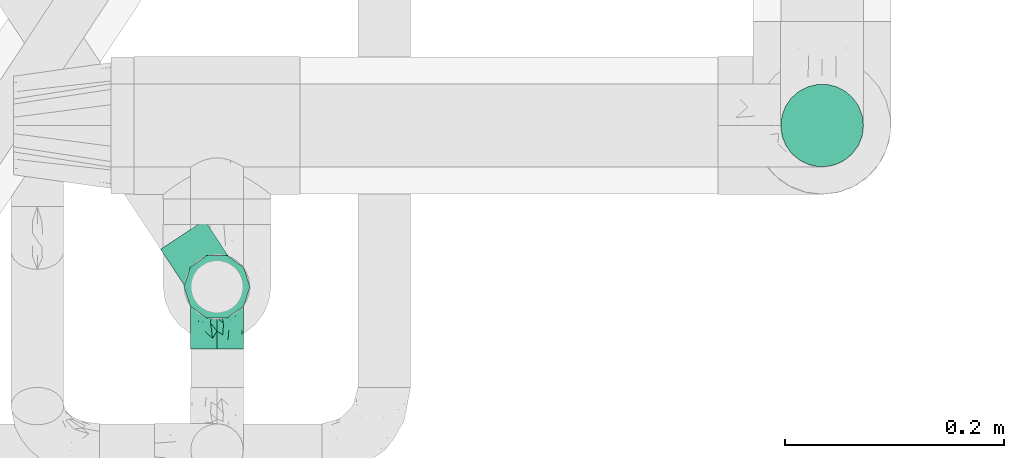
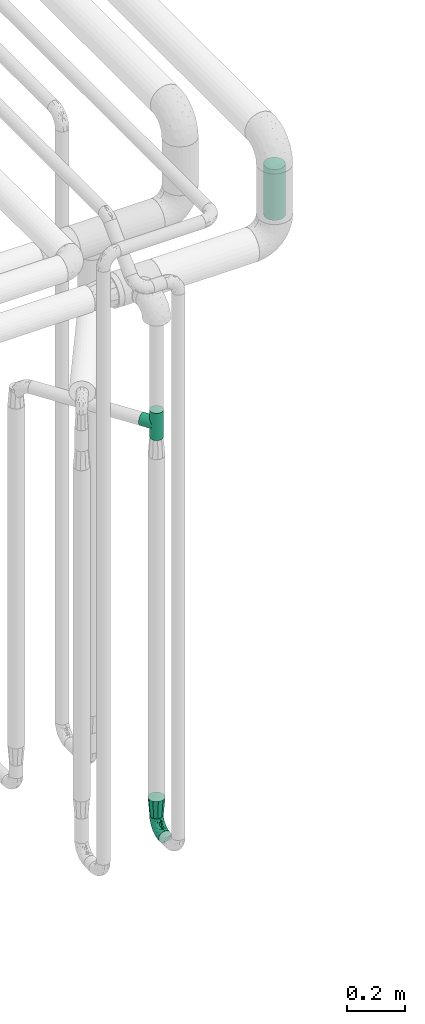
# One storey, part 667 of 827: 3 flow fittings, 1 flow segment.
"""IFC2X3 building model written with IfcOpenShell, lengths in millimetres."""

from ifc_helpers import new_model, entity, si_unit, converted_unit, derived_unit, direction, frame, origin, origin_2d_with_axis, place, context, subcontext, project, spatial, circle, extrude, faceted_brep, source, transform, mapped, material, type_object, type_shapes, element, save


model = new_model("IFC2X3")

# Units and contexts
model_context = context("Model", 3, precision=0.01, world=origin(), true_north=direction((6.12303176911189e-17, 1.0)))
body_context = subcontext(model_context, "Body", "Model", "MODEL_VIEW")
ifc_project = project(units=[si_unit("LENGTHUNIT", "METRE", prefix="MILLI"), si_unit("AREAUNIT", "SQUARE_METRE"), si_unit("VOLUMEUNIT", "CUBIC_METRE"), converted_unit("PLANEANGLEUNIT", "DEGREE", entity("IfcRatioMeasure", 0.0174532925199433), si_unit("PLANEANGLEUNIT", "RADIAN"), dimensions=[0, 0, 0, 0, 0, 0, 0]), si_unit("MASSUNIT", "GRAM", prefix="KILO"), derived_unit("MASSDENSITYUNIT", [(si_unit("MASSUNIT", "GRAM", prefix="KILO"), 1), (si_unit("LENGTHUNIT", "METRE"), -3)]), derived_unit("MOMENTOFINERTIAUNIT", [(si_unit("LENGTHUNIT", "METRE"), 4)]), si_unit("TIMEUNIT", "SECOND"), si_unit("FREQUENCYUNIT", "HERTZ"), si_unit("THERMODYNAMICTEMPERATUREUNIT", "DEGREE_CELSIUS"), derived_unit("THERMALTRANSMITTANCEUNIT", [(si_unit("MASSUNIT", "GRAM", prefix="KILO"), 1), (si_unit("THERMODYNAMICTEMPERATUREUNIT", "KELVIN"), -1), (si_unit("TIMEUNIT", "SECOND"), -3)]), derived_unit("VOLUMETRICFLOWRATEUNIT", [(si_unit("LENGTHUNIT", "METRE"), 3), (si_unit("TIMEUNIT", "SECOND"), -1)]), derived_unit("MASSFLOWRATEUNIT", [(si_unit("MASSUNIT", "GRAM", prefix="KILO"), 1), (si_unit("TIMEUNIT", "SECOND"), -1)]), derived_unit("ROTATIONALFREQUENCYUNIT", [(si_unit("TIMEUNIT", "SECOND"), -1)]), si_unit("ELECTRICCURRENTUNIT", "AMPERE"), si_unit("ELECTRICVOLTAGEUNIT", "VOLT"), si_unit("POWERUNIT", "WATT"), si_unit("FORCEUNIT", "NEWTON", prefix="KILO"), si_unit("ILLUMINANCEUNIT", "LUX"), si_unit("LUMINOUSFLUXUNIT", "LUMEN"), si_unit("LUMINOUSINTENSITYUNIT", "CANDELA"), derived_unit("USERDEFINED", [(si_unit("MASSUNIT", "GRAM", prefix="KILO"), -1), (si_unit("LENGTHUNIT", "METRE"), -2), (si_unit("TIMEUNIT", "SECOND"), 3), (si_unit("LUMINOUSFLUXUNIT", "LUMEN"), 1)]), derived_unit("LINEARVELOCITYUNIT", [(si_unit("LENGTHUNIT", "METRE"), 1), (si_unit("TIMEUNIT", "SECOND"), -1)]), si_unit("PRESSUREUNIT", "PASCAL"), derived_unit("USERDEFINED", [(si_unit("LENGTHUNIT", "METRE"), -2), (si_unit("MASSUNIT", "GRAM", prefix="KILO"), 1), (si_unit("TIMEUNIT", "SECOND"), -2)]), derived_unit("LINEARFORCEUNIT", [(si_unit("MASSUNIT", "GRAM", prefix="KILO"), 1), (si_unit("LENGTHUNIT", "METRE"), 1), (si_unit("TIMEUNIT", "SECOND"), -2), (si_unit("LENGTHUNIT", "METRE"), -1)]), derived_unit("PLANARFORCEUNIT", [(si_unit("MASSUNIT", "GRAM", prefix="KILO"), 1), (si_unit("LENGTHUNIT", "METRE"), 1), (si_unit("TIMEUNIT", "SECOND"), -2), (si_unit("LENGTHUNIT", "METRE"), -2)])], contexts=[model_context])

# Site, building, storey
site_placement = place(None, origin())
site = spatial("IfcSite", under=ifc_project, at=site_placement, CompositionType="ELEMENT")
building_placement = place(site_placement, origin())
building = spatial("IfcBuilding", under=site, at=building_placement, CompositionType="ELEMENT")
storey_placement = place(building_placement, frame((0.0, 0.0, 28200.0)))
storey = spatial("IfcBuildingStorey", under=building, at=storey_placement, Name="08", CompositionType="ELEMENT", Elevation=28200.0)

# Flow segment
pipe_segment_type = type_object("IfcPipeSegmentType", PredefinedType="NOTDEFINED")
flow_segment_placement = place(storey_placement, frame((48805.69, 13894.16, 2692.43)))
element("IfcFlowSegment", 1, at=flow_segment_placement, inside=storey, type_object=pipe_segment_type, context=body_context, shape_type="SweptSolid", body=[
    extrude(circle(Radius=37.75, at=origin_2d_with_axis()), frame((39.35, 39.35, 0.0)), (0.0, 0.0, 1.0), 212.567197891267),
])

# Flow fittings
ifc_material = material()
pipe_fitting_type_1 = type_object("IfcPipeFittingType", Name="ADSK_1", PredefinedType="NOTDEFINED", material=ifc_material)
shared_shape_1 = source(origin(), body_context, "Body", "Brep", [
    faceted_brep([(-57.0, 12.07, -20.91), (-57.0, 6.25, -23.33), (-57.0, 0.0, -24.15), (-57.0, -6.25, -23.33), (-57.0, -12.08, -20.91), (-57.0, -17.08, -17.08), (-57.0, -20.91, -12.08), (-57.0, -23.33, -6.25), (-57.0, -24.15, 0.0), (-57.0, -23.33, 6.25), (-57.0, -20.91, 12.07), (-57.0, -17.08, 17.08), (-57.0, -12.08, 20.91), (-57.0, -6.25, 23.33), (-57.0, 0.0, 24.15), (-57.0, 6.25, 23.33), (-57.0, 12.07, 20.91), (-57.0, 17.08, 17.08), (-57.0, 20.91, 12.07), (-57.0, 23.33, 6.25), (-57.0, 24.15, 0.0), (-57.0, 23.33, -6.25), (-57.0, 20.91, -12.08), (-57.0, 17.08, -17.08), (0.0, 57.0, -24.15), (-6.25, 57.0, -23.33), (-12.07, 57.0, -20.91), (-17.08, 57.0, -17.08), (-20.91, 57.0, -12.08), (-23.33, 57.0, -6.25), (-24.15, 57.0, 0.0), (-23.33, 57.0, 6.25), (-20.91, 57.0, 12.07), (-17.08, 57.0, 17.08), (-12.07, 57.0, 20.91), (-6.25, 57.0, 23.33), (0.0, 57.0, 24.15), (6.25, 57.0, 23.33), (12.08, 57.0, 20.91), (17.08, 57.0, 17.08), (20.91, 57.0, 12.07), (23.33, 57.0, 6.25), (24.15, 57.0, 0.0), (23.33, 57.0, -6.25), (20.91, 57.0, -12.08), (17.08, 57.0, -17.08), (12.08, 57.0, -20.91), (6.25, 57.0, -23.33), (14.9, 21.14, 6.17), (13.61, 24.64, 12.48), (6.23, 8.95, 8.98), (-41.47, -21.06, 0.0), (-41.92, -18.38, 13.72), (-24.64, -13.61, 12.48), (-37.37, -13.24, 18.15), (-6.8, -4.93, 8.18), (-21.76, -15.19, 6.22), (-12.78, -9.18, 0.0), (-37.73, -20.51, 7.75), (-7.38, 7.38, 20.24), (-23.37, -4.26, 20.42), (-11.9, -3.19, 15.86), (-42.14, -8.7, 21.82), (13.24, 37.37, 18.15), (9.33, 23.53, 16.85), (4.26, 23.37, 20.42), (2.77, 10.92, 15.55), (-29.46, 0.91, 23.52), (-44.13, 20.56, 15.69), (-39.25, 26.33, 10.88), (-49.02, 22.92, 9.96), (-34.58, 23.87, 17.15), (-15.8, 6.8, 22.81), (-8.67, 20.47, 23.88), (-18.12, 12.9, 24.08), (-48.29, 14.92, 19.65), (-44.06, -2.85, 23.78), (-9.23, 48.95, 22.58), (-3.78, 42.74, 24.07), (-40.34, 4.26, 24.09), (-44.02, 26.14, 5.46), (-44.04, 9.88, 22.74), (-4.95, 16.87, 22.52), (-2.75, 1.43, 12.5), (-25.48, 40.98, 10.71), (20.51, 37.73, 7.75), (18.38, 41.92, 13.72), (8.7, 42.14, 21.82), (-25.95, -17.97, 0.0), (2.85, 44.06, 23.78), (21.06, 41.47, 0.0), (17.97, 25.95, 0.0), (-24.04, -9.27, 17.13), (-33.26, 33.26, 5.86), (-28.55, 40.57, 0.0), (-40.57, 28.55, 0.0), (-25.29, 47.19, 4.06), (-27.01, 31.1, 16.77), (-15.7, 43.95, 19.9), (-20.27, 45.22, 15.61), (-30.53, 31.98, 12.64), (-11.28, 38.33, 22.92), (-9.97, 27.88, 24.09), (-20.15, 30.26, 21.25), (-31.25, 11.75, 23.64), (-28.75, 7.23, 24.15), (-29.53, 18.06, 22.27), (-28.44, 24.21, 20.02), (-37.55, 17.7, 20.26), (-15.88, 29.25, 22.99), (-20.82, 20.82, 23.44), (-0.91, 29.46, 23.52), (-13.5, -7.67, 12.04), (1.49, 1.56, 5.16), (8.86, 10.35, 4.59), (0.38, -0.38, 0.0), (9.18, 12.78, 0.0), (-37.37, -13.24, -18.15), (8.86, 10.35, -4.59), (-45.22, 20.27, -15.61), (-43.95, 15.7, -19.9), (-38.33, 11.28, -22.92), (-48.95, 9.23, -22.58), (-47.19, 25.29, -4.06), (-33.26, 33.26, -5.86), (18.38, 41.92, -13.72), (-30.26, 20.15, -21.25), (2.85, 44.06, -23.78), (-4.26, 40.34, -24.09), (-40.98, 25.48, -10.71), (-41.92, -18.38, -13.72), (9.25, 23.5, -16.92), (4.26, 23.37, -20.42), (13.24, 37.37, -18.15), (-37.73, -20.51, -7.75), (-11.75, 31.25, -23.64), (-7.23, 28.75, -24.15), (-12.9, 18.12, -24.08), (8.7, 42.14, -21.82), (-44.06, -2.85, -23.78), (-6.8, 15.8, -22.81), (-20.47, 8.67, -23.88), (-24.64, -13.61, -12.48), (-42.74, 3.78, -24.07), (-18.06, 29.53, -22.27), (-24.21, 28.44, -20.02), (-27.88, 9.97, -24.09), (-31.1, 27.01, -16.77), (-26.14, 44.02, -5.46), (14.9, 21.14, -6.17), (20.51, 37.73, -7.75), (-9.88, 44.04, -22.74), (-20.56, 44.13, -15.69), (-21.76, -15.19, -6.22), (-13.5, -7.67, -12.04), (-24.14, -9.76, -16.74), (-11.9, -3.19, -15.86), (-14.92, 48.29, -19.65), (-23.37, -4.26, -20.42), (-0.91, 29.46, -23.52), (-26.33, 39.25, -10.88), (-23.87, 34.58, -17.15), (-42.14, -8.7, -21.82), (-22.92, 49.02, -9.96), (13.61, 24.64, -12.48), (-31.98, 30.53, -12.64), (-16.87, 4.95, -22.52), (-17.7, 37.55, -20.26), (-29.25, 15.88, -22.99), (-20.82, 20.82, -23.44), (-29.46, 0.91, -23.52), (-7.38, 7.38, -20.24), (2.77, 10.92, -15.55), (6.23, 8.95, -8.98), (-6.8, -4.93, -8.18), (-2.81, 1.41, -12.54), (1.49, 1.56, -5.16)], [[[0, 1, 2, 3, 4, 5, 6, 7, 8, 9, 10, 11, 12, 13, 14, 15, 16, 17, 18, 19, 20, 21, 22, 23]], [[24, 25, 26, 27, 28, 29, 30, 31, 32, 33, 34, 35, 36, 37, 38, 39, 40, 41, 42, 43, 44, 45, 46, 47]], [[48, 49, 50]], [[9, 8, 51]], [[52, 53, 54]], [[55, 56, 57]], [[10, 58, 52]], [[9, 58, 10]], [[59, 60, 61]], [[54, 12, 11]], [[54, 62, 12]], [[63, 39, 38]], [[64, 65, 66]], [[62, 60, 67]], [[68, 69, 70]], [[71, 69, 68]], [[72, 73, 74]], [[16, 75, 17]], [[13, 76, 14]], [[35, 77, 78]], [[14, 79, 15]], [[17, 68, 18]], [[14, 76, 79]], [[20, 19, 80]], [[70, 19, 18]], [[81, 15, 79]], [[15, 81, 16]], [[73, 72, 82]], [[66, 83, 50]], [[32, 31, 84]], [[85, 86, 49]], [[63, 87, 65]], [[56, 58, 88]], [[36, 89, 37]], [[85, 41, 40]], [[36, 35, 78]], [[90, 41, 85]], [[40, 39, 86]], [[12, 62, 13]], [[86, 85, 40]], [[48, 85, 49]], [[85, 91, 90]], [[87, 38, 37]], [[92, 60, 54]], [[80, 69, 93]], [[93, 94, 95]], [[10, 52, 11]], [[94, 96, 30]], [[97, 98, 99]], [[80, 93, 95]], [[100, 97, 84]], [[99, 98, 33]], [[101, 102, 78]], [[103, 101, 98]], [[96, 31, 30]], [[77, 98, 101]], [[77, 35, 34]], [[34, 33, 98]], [[9, 51, 58]], [[87, 63, 38]], [[104, 105, 74]], [[106, 103, 107]], [[106, 81, 104]], [[75, 68, 17]], [[108, 107, 71]], [[33, 32, 99]], [[109, 103, 110]], [[101, 109, 102]], [[89, 78, 111]], [[53, 52, 58]], [[54, 11, 52]], [[60, 62, 54]], [[88, 58, 51]], [[76, 62, 67]], [[53, 112, 92]], [[60, 59, 72]], [[39, 63, 86]], [[49, 86, 63]], [[89, 87, 37]], [[42, 41, 90]], [[111, 82, 65]], [[111, 65, 87]], [[65, 59, 66]], [[104, 81, 79]], [[75, 81, 108]], [[32, 84, 99]], [[97, 99, 84]], [[98, 97, 103]], [[106, 107, 108]], [[74, 102, 110]], [[111, 78, 102]], [[74, 110, 104]], [[74, 67, 72]], [[61, 92, 112]], [[66, 59, 61]], [[56, 53, 58]], [[66, 50, 49]], [[61, 112, 83]], [[66, 49, 64]], [[78, 89, 36]], [[87, 89, 111]], [[62, 76, 13]], [[79, 76, 67]], [[100, 93, 69]], [[96, 93, 84]], [[55, 113, 50]], [[113, 114, 50]], [[104, 79, 105]], [[106, 104, 110]], [[20, 80, 95]], [[85, 48, 91]], [[115, 114, 113]], [[116, 91, 48]], [[70, 80, 19]], [[93, 96, 94]], [[84, 31, 96]], [[103, 106, 110]], [[81, 106, 108]], [[103, 97, 107]], [[71, 107, 97]], [[71, 97, 100]], [[108, 71, 68]], [[79, 67, 105]], [[67, 74, 105]], [[115, 113, 57]], [[112, 56, 55]], [[56, 88, 57]], [[60, 72, 67]], [[82, 72, 59]], [[65, 82, 59]], [[82, 111, 73]], [[111, 102, 73]], [[102, 74, 73]], [[81, 75, 16]], [[68, 75, 108]], [[68, 70, 18]], [[80, 70, 69]], [[98, 77, 34]], [[78, 77, 101]], [[93, 100, 84]], [[71, 100, 69]], [[102, 109, 110]], [[101, 103, 109]], [[53, 92, 54]], [[61, 60, 92]], [[56, 112, 53]], [[83, 112, 55]], [[50, 83, 55]], [[61, 83, 66]], [[49, 63, 64]], [[65, 64, 63]], [[57, 113, 55]], [[114, 115, 116]], [[116, 48, 114]], [[48, 50, 114]], [[117, 5, 4]], [[116, 115, 118]], [[119, 120, 23]], [[121, 122, 120]], [[95, 123, 20]], [[0, 23, 120]], [[124, 95, 94]], [[125, 45, 44]], [[121, 120, 126]], [[24, 127, 128]], [[22, 21, 129]], [[0, 122, 1]], [[5, 117, 130]], [[131, 132, 133]], [[134, 88, 51]], [[135, 136, 137]], [[6, 5, 130]], [[46, 138, 47]], [[139, 3, 2]], [[140, 141, 137]], [[6, 134, 7]], [[134, 130, 142]], [[143, 2, 1]], [[144, 126, 145]], [[121, 146, 143]], [[147, 120, 119]], [[94, 148, 124]], [[149, 150, 91]], [[30, 29, 148]], [[151, 25, 128]], [[27, 152, 28]], [[134, 153, 88]], [[154, 155, 156]], [[27, 26, 157]], [[151, 26, 25]], [[155, 158, 156]], [[24, 47, 127]], [[1, 122, 143]], [[138, 132, 159]], [[160, 152, 161]], [[24, 128, 25]], [[46, 133, 138]], [[162, 117, 4]], [[148, 160, 124]], [[152, 160, 163]], [[154, 142, 155]], [[45, 125, 133]], [[133, 46, 45]], [[125, 164, 133]], [[51, 7, 134]], [[42, 90, 43]], [[165, 147, 129]], [[153, 134, 142]], [[43, 150, 44]], [[162, 4, 3]], [[141, 140, 166]], [[117, 162, 158]], [[163, 29, 28]], [[43, 90, 150]], [[123, 21, 20]], [[144, 151, 135]], [[157, 152, 27]], [[167, 145, 161]], [[23, 22, 119]], [[168, 126, 169]], [[121, 168, 146]], [[139, 143, 170]], [[142, 130, 117]], [[8, 7, 51]], [[134, 6, 130]], [[139, 162, 3]], [[170, 166, 158]], [[170, 158, 162]], [[158, 171, 156]], [[44, 150, 125]], [[91, 150, 90]], [[164, 125, 150]], [[132, 138, 133]], [[127, 138, 159]], [[131, 164, 172]], [[132, 171, 140]], [[135, 151, 128]], [[157, 151, 167]], [[22, 129, 119]], [[147, 119, 129]], [[120, 147, 126]], [[144, 145, 167]], [[137, 146, 169]], [[170, 143, 146]], [[137, 169, 135]], [[137, 159, 140]], [[171, 172, 156]], [[173, 174, 175]], [[156, 175, 154]], [[174, 57, 153]], [[132, 172, 171]], [[172, 164, 173]], [[143, 139, 2]], [[162, 139, 170]], [[138, 127, 47]], [[128, 127, 159]], [[165, 124, 160]], [[123, 124, 129]], [[149, 173, 164]], [[176, 174, 173]], [[135, 128, 136]], [[144, 135, 169]], [[150, 149, 164]], [[176, 118, 115]], [[149, 91, 116]], [[30, 148, 94]], [[163, 148, 29]], [[124, 123, 95]], [[129, 21, 123]], [[126, 144, 169]], [[151, 144, 167]], [[126, 147, 145]], [[161, 145, 147]], [[161, 147, 165]], [[167, 161, 152]], [[128, 159, 136]], [[159, 137, 136]], [[154, 153, 142]], [[132, 140, 159]], [[174, 176, 57]], [[57, 88, 153]], [[166, 140, 171]], [[158, 166, 171]], [[166, 170, 141]], [[170, 146, 141]], [[146, 137, 141]], [[151, 157, 26]], [[152, 157, 167]], [[152, 163, 28]], [[148, 163, 160]], [[120, 122, 0]], [[143, 122, 121]], [[124, 165, 129]], [[161, 165, 160]], [[146, 168, 169]], [[121, 126, 168]], [[142, 117, 155]], [[158, 155, 117]], [[175, 156, 172]], [[153, 154, 174]], [[173, 175, 172]], [[174, 154, 175]], [[164, 131, 133]], [[172, 132, 131]], [[176, 173, 118]], [[57, 176, 115]], [[173, 149, 118]], [[149, 116, 118]]]),
])
type_shapes(pipe_fitting_type_1, [shared_shape_1])
flow_fitting_1_placement = place(storey_placement, frame((48292.03, 13786.1, 400.0), z_axis=(1.0, 0.0, 3.35752990107202e-06), x_axis=(0.0, 1.0, 0.0)))
element("IfcFlowFitting", 2, at=flow_fitting_1_placement, inside=storey, type_object=pipe_fitting_type_1, material=ifc_material, Name="ADSK_1", ObjectType="ADSK_1", context=body_context, shape_type="MappedRepresentation", body=[
    mapped(shared_shape_1, transform((0.0, 0.0, 0.0), scale=1.0)),
])
pipe_fitting_type_2 = type_object("IfcPipeFittingType", Name="ADSK_1", PredefinedType="NOTDEFINED", material=ifc_material)
shared_shape_2 = source(origin(), body_context, "Body", "Brep", [
    faceted_brep([(-57.0, 12.07, -20.91), (-57.0, 6.25, -23.33), (-57.0, 0.0, -24.15), (-57.0, -6.25, -23.33), (-57.0, -12.08, -20.91), (-57.0, -17.08, -17.08), (-57.0, -20.91, -12.08), (-57.0, -23.33, -6.25), (-57.0, -24.15, 0.0), (-57.0, -23.33, 6.25), (-57.0, -20.91, 12.07), (-57.0, -17.08, 17.08), (-57.0, -12.08, 20.91), (-57.0, -6.25, 23.33), (-57.0, 0.0, 24.15), (-57.0, 6.25, 23.33), (-57.0, 12.07, 20.91), (-57.0, 17.08, 17.08), (-57.0, 20.91, 12.07), (-57.0, 23.33, 6.25), (-57.0, 24.15, 0.0), (-57.0, 23.33, -6.25), (-57.0, 20.91, -12.08), (-57.0, 17.08, -17.08), (57.0, 0.0, -24.15), (57.0, 6.25, -23.33), (57.0, 12.07, -20.91), (57.0, 17.08, -17.08), (57.0, 20.91, -12.08), (57.0, 23.33, -6.25), (57.0, 24.15, 0.0), (57.0, 23.33, 6.25), (57.0, 20.91, 12.07), (57.0, 17.08, 17.08), (57.0, 12.07, 20.91), (57.0, 6.25, 23.33), (57.0, 0.0, 24.15), (57.0, -6.25, 23.33), (57.0, -12.08, 20.91), (57.0, -17.08, 17.08), (57.0, -20.91, 12.07), (57.0, -23.33, 6.25), (57.0, -24.15, 0.0), (57.0, -23.33, -6.25), (57.0, -20.91, -12.08), (57.0, -17.08, -17.08), (57.0, -12.08, -20.91), (57.0, -6.25, -23.33), (23.27, -23.27, 6.45), (24.15, -24.15, 0.0), (-24.15, -24.15, 0.0), (20.9, -20.9, 12.1), (13.54, -13.54, 20.0), (17.52, -17.52, 16.62), (-23.27, -23.27, 6.45), (-20.9, -20.9, 12.1), (-17.52, -17.52, 16.62), (-13.54, -13.54, 20.0), (-9.19, -9.19, 22.33), (9.19, -9.19, 22.33), (4.64, -4.64, 23.7), (0.0, 0.0, 24.15), (-4.64, -4.64, 23.7), (4.64, -4.64, -23.7), (0.0, 0.0, -24.15), (-4.64, -4.64, -23.7), (-9.19, -9.19, -22.33), (9.19, -9.19, -22.33), (13.54, -13.54, -20.0), (17.52, -17.52, -16.62), (20.9, -20.9, -12.1), (23.27, -23.27, -6.45), (-13.54, -13.54, -20.0), (-17.52, -17.52, -16.62), (-23.27, -23.27, -6.45), (-20.9, -20.9, -12.1), (0.0, -57.0, -24.15), (6.25, -57.0, -23.33), (12.08, -57.0, -20.91), (17.08, -57.0, -17.08), (20.91, -57.0, -12.08), (23.33, -57.0, -6.25), (24.15, -57.0, 0.0), (23.33, -57.0, 6.25), (20.91, -57.0, 12.07), (17.08, -57.0, 17.08), (12.08, -57.0, 20.91), (6.25, -57.0, 23.33), (0.0, -57.0, 24.15), (-6.25, -57.0, 23.33), (-12.07, -57.0, 20.91), (-17.08, -57.0, 17.08), (-20.91, -57.0, 12.07), (-23.33, -57.0, 6.25), (-24.15, -57.0, 0.0), (-23.33, -57.0, -6.25), (-20.91, -57.0, -12.08), (-17.08, -57.0, -17.08), (-12.07, -57.0, -20.91), (-6.25, -57.0, -23.33)], [[[0, 1, 2, 3, 4, 5, 6, 7, 8, 9, 10, 11, 12, 13, 14, 15, 16, 17, 18, 19, 20, 21, 22, 23]], [[24, 25, 26, 27, 28, 29, 30, 31, 32, 33, 34, 35, 36, 37, 38, 39, 40, 41, 42, 43, 44, 45, 46, 47]], [[41, 40, 48]], [[42, 41, 49]], [[50, 9, 8]], [[49, 41, 48]], [[40, 51, 48]], [[39, 38, 52]], [[51, 40, 53]], [[52, 53, 39]], [[53, 40, 39]], [[50, 54, 9]], [[9, 54, 10]], [[54, 55, 10]], [[56, 57, 11]], [[11, 10, 56]], [[11, 57, 12]], [[56, 10, 55]], [[12, 57, 58]], [[52, 38, 59]], [[60, 36, 61]], [[62, 61, 14]], [[59, 37, 60]], [[37, 59, 38]], [[60, 37, 36]], [[61, 36, 35, 15, 14]], [[32, 31, 19, 18]], [[17, 16, 34, 33]], [[18, 17, 33, 32]], [[35, 34, 16, 15]], [[20, 19, 31, 30]], [[62, 13, 58]], [[13, 62, 14]], [[58, 13, 12]], [[27, 23, 22, 28]], [[22, 21, 29, 28]], [[0, 23, 27, 26]], [[20, 30, 29, 21]], [[24, 47, 63]], [[24, 64, 2, 1, 25]], [[64, 24, 63]], [[2, 64, 65]], [[26, 25, 1, 0]], [[65, 66, 3]], [[2, 65, 3]], [[66, 4, 3]], [[63, 47, 67]], [[46, 45, 68]], [[69, 68, 45]], [[44, 70, 69]], [[69, 45, 44]], [[46, 68, 67]], [[43, 42, 49]], [[7, 50, 8]], [[43, 71, 44]], [[71, 43, 49]], [[44, 71, 70]], [[72, 4, 66]], [[72, 5, 4]], [[5, 72, 73]], [[5, 73, 6]], [[74, 50, 7]], [[75, 74, 6]], [[74, 7, 6]], [[75, 6, 73]], [[46, 67, 47]], [[76, 77, 78, 79, 80, 81, 82, 83, 84, 85, 86, 87, 88, 89, 90, 91, 92, 93, 94, 95, 96, 97, 98, 99]], [[50, 94, 93]], [[54, 50, 93]], [[91, 90, 57]], [[56, 92, 91]], [[54, 93, 92]], [[58, 90, 89]], [[55, 54, 92]], [[56, 55, 92]], [[58, 57, 90]], [[88, 61, 62]], [[58, 89, 62]], [[56, 91, 57]], [[62, 89, 88]], [[60, 88, 87]], [[86, 59, 87]], [[84, 83, 48]], [[53, 85, 84]], [[52, 86, 85]], [[49, 83, 82]], [[59, 60, 87]], [[52, 59, 86]], [[49, 48, 83]], [[51, 53, 84]], [[48, 51, 84]], [[52, 85, 53]], [[88, 60, 61]], [[82, 81, 49]], [[71, 49, 81]], [[69, 80, 79]], [[79, 78, 68]], [[71, 81, 80]], [[67, 78, 77]], [[70, 71, 80]], [[69, 70, 80]], [[67, 68, 78]], [[76, 64, 63]], [[67, 77, 63]], [[69, 79, 68]], [[63, 77, 76]], [[65, 76, 99]], [[98, 66, 99]], [[96, 95, 74]], [[73, 97, 96]], [[72, 98, 97]], [[50, 95, 94]], [[66, 65, 99]], [[72, 66, 98]], [[50, 74, 95]], [[75, 73, 96]], [[74, 75, 96]], [[72, 97, 73]], [[76, 65, 64]]]),
])
type_shapes(pipe_fitting_type_2, [shared_shape_2])
flow_fitting_2_placement = place(storey_placement, frame((48292.03, 13786.1, 2100.0), z_axis=(-0.834213762790336, -0.551441200623111, -1.50509593130188e-05), x_axis=(1.23334445776662e-05, 8.63597079186445e-06, -1.0)))
element("IfcFlowFitting", 3, at=flow_fitting_2_placement, inside=storey, type_object=pipe_fitting_type_2, material=ifc_material, Name="ADSK_1", ObjectType="ADSK_1", context=body_context, shape_type="MappedRepresentation", body=[
    mapped(shared_shape_2, transform((0.0, 0.0, 0.0), scale=1.0)),
])
pipe_fitting_type_3 = type_object("IfcPipeFittingType", Name="ADSK_1", PredefinedType="NOTDEFINED", material=ifc_material)
shared_shape_3 = source(origin(), body_context, "Body", "Brep", [
    faceted_brep([(76.0, -30.15, 0.0), (76.0, -28.24, -5.87), (76.0, -26.33, -11.75), (76.0, -24.39, -17.72), (76.0, -16.85, -23.2), (76.0, -9.32, -28.67), (76.0, 0.0, -28.67), (76.0, 9.32, -28.67), (76.0, 16.85, -23.2), (76.0, 24.39, -17.72), (76.0, 26.33, -11.75), (76.0, 28.24, -5.87), (76.0, 30.15, 0.0), (76.0, 28.24, 5.87), (76.0, 26.33, 11.75), (76.0, 24.39, 17.72), (76.0, 16.85, 23.2), (76.0, 9.32, 28.67), (76.0, 0.0, 28.67), (76.0, -9.32, 28.67), (76.0, -16.85, 23.2), (76.0, -24.39, 17.72), (76.0, -26.33, 11.75), (76.0, -28.24, 5.87), (0.0, -19.54, -14.2), (0.0, -21.84, -7.1), (0.0, -24.15, 0.0), (0.0, -21.84, 7.1), (0.0, -19.54, 14.2), (0.0, -13.5, 18.58), (0.0, -7.46, 22.97), (0.0, 0.0, 22.97), (0.0, 7.46, 22.97), (0.0, 13.5, 18.58), (0.0, 19.54, 14.2), (0.0, 21.84, 7.1), (0.0, 24.15, 0.0), (0.0, 21.84, -7.1), (0.0, 19.54, -14.2), (0.0, 13.5, -18.58), (0.0, 7.46, -22.97), (0.0, 0.0, -22.97), (0.0, -7.46, -22.97), (0.0, -13.5, -18.58)], [[[0, 1, 2, 3, 4, 5, 6, 7, 8, 9, 10, 11, 12, 13, 14, 15, 16, 17, 18, 19, 20, 21, 22, 23]], [[24, 25, 26, 27, 28, 29, 30, 31, 32, 33, 34, 35, 36, 37, 38, 39, 40, 41, 42, 43]], [[24, 3, 2, 1, 0, 26, 25]], [[7, 40, 39, 38, 9, 8]], [[42, 5, 4, 3, 24, 43]], [[6, 5, 42, 41, 40, 7]], [[11, 10, 9, 38, 37, 36, 12]], [[34, 15, 14, 13, 12, 36, 35]], [[19, 30, 29, 28, 21, 20]], [[32, 17, 16, 15, 34, 33]], [[18, 17, 32, 31, 30, 19]], [[23, 22, 21, 28, 27, 26, 0]]]),
])
type_shapes(pipe_fitting_type_3, [shared_shape_3])
flow_fitting_3_placement = place(storey_placement, frame((48292.03, 13786.1, 457.0), z_axis=(0.0, 1.0, 0.0), x_axis=(-3.35752990107202e-06, 0.0, 1.0)))
element("IfcFlowFitting", 4, at=flow_fitting_3_placement, inside=storey, type_object=pipe_fitting_type_3, material=ifc_material, Name="ADSK_1", ObjectType="ADSK_1", context=body_context, shape_type="MappedRepresentation", body=[
    mapped(shared_shape_3, transform((0.0, 0.0, 0.0), scale=1.0)),
])

save(model, "model.ifc")
